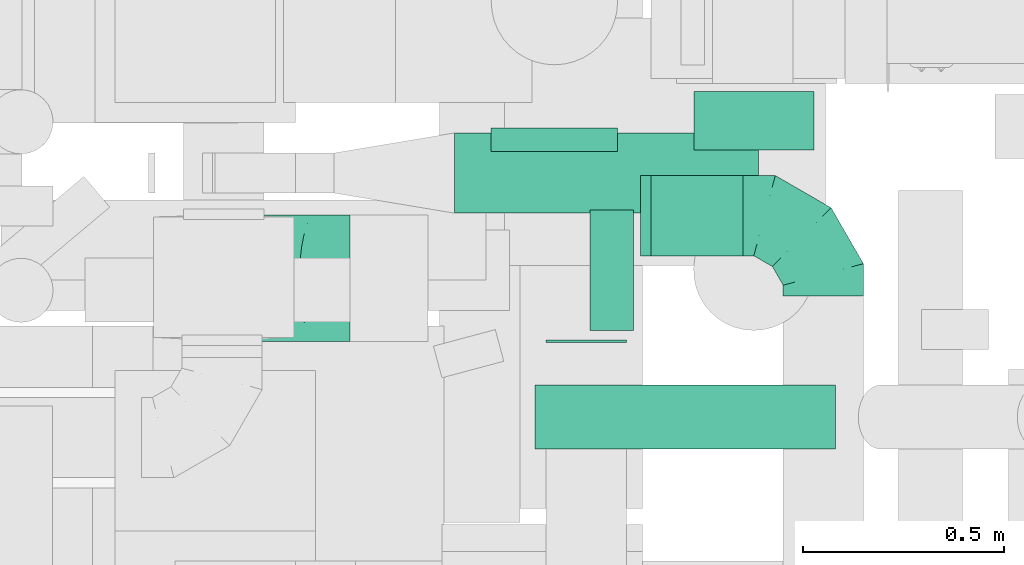
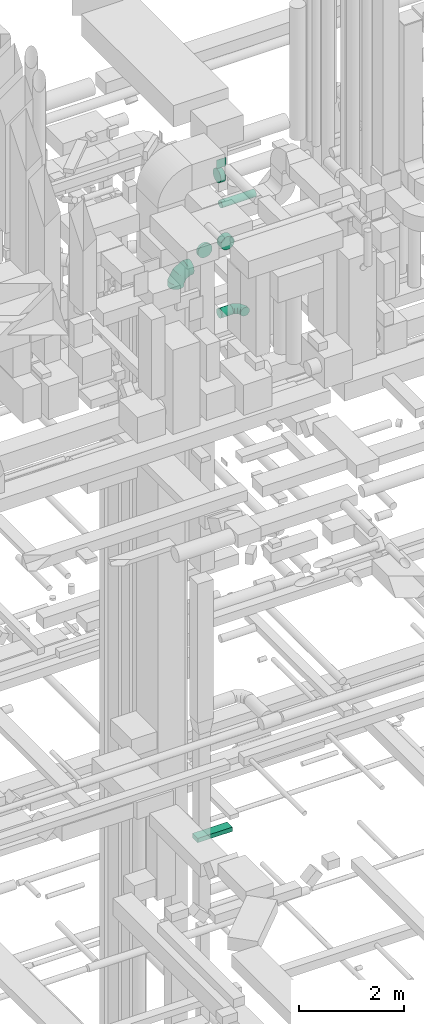
# One storey, part 198 of 337: 7 flow segments, 3 flow fittings.
"""IFC2X3 building model written with IfcOpenShell, lengths in millimetres."""

from ifc_helpers import new_model, entity, si_unit, converted_unit, derived_unit, direction, frame, origin, origin_2d_with_axis, place, context, subcontext, project, spatial, rectangle, circle, extrude, faceted_brep, source, transform, mapped, material, type_object, type_shapes, element, save


model = new_model("IFC2X3")

# Units and contexts
model_context = context("Model", 3, precision=0.01, world=origin(), true_north=direction((6.12303176911189e-17, 1.0)))
body_context = subcontext(model_context, "Body", "Model", "MODEL_VIEW")
ifc_project = project(units=[si_unit("LENGTHUNIT", "METRE", prefix="MILLI"), si_unit("AREAUNIT", "SQUARE_METRE"), si_unit("VOLUMEUNIT", "CUBIC_METRE"), converted_unit("PLANEANGLEUNIT", "DEGREE", entity("IfcRatioMeasure", 0.0174532925199433), si_unit("PLANEANGLEUNIT", "RADIAN"), dimensions=[0, 0, 0, 0, 0, 0, 0]), si_unit("MASSUNIT", "GRAM", prefix="KILO"), derived_unit("MASSDENSITYUNIT", [(si_unit("MASSUNIT", "GRAM", prefix="KILO"), 1), (si_unit("LENGTHUNIT", "METRE"), -3)]), derived_unit("MOMENTOFINERTIAUNIT", [(si_unit("LENGTHUNIT", "METRE"), 4)]), si_unit("TIMEUNIT", "SECOND"), si_unit("FREQUENCYUNIT", "HERTZ"), si_unit("THERMODYNAMICTEMPERATUREUNIT", "DEGREE_CELSIUS"), derived_unit("THERMALTRANSMITTANCEUNIT", [(si_unit("MASSUNIT", "GRAM", prefix="KILO"), 1), (si_unit("THERMODYNAMICTEMPERATUREUNIT", "KELVIN"), -1), (si_unit("TIMEUNIT", "SECOND"), -3)]), derived_unit("VOLUMETRICFLOWRATEUNIT", [(si_unit("LENGTHUNIT", "METRE"), 3), (si_unit("TIMEUNIT", "SECOND"), -1)]), derived_unit("MASSFLOWRATEUNIT", [(si_unit("MASSUNIT", "GRAM", prefix="KILO"), 1), (si_unit("TIMEUNIT", "SECOND"), -1)]), derived_unit("ROTATIONALFREQUENCYUNIT", [(si_unit("TIMEUNIT", "SECOND"), -1)]), si_unit("ELECTRICCURRENTUNIT", "AMPERE"), si_unit("ELECTRICVOLTAGEUNIT", "VOLT"), si_unit("POWERUNIT", "WATT"), si_unit("FORCEUNIT", "NEWTON", prefix="KILO"), si_unit("ILLUMINANCEUNIT", "LUX"), si_unit("LUMINOUSFLUXUNIT", "LUMEN"), si_unit("LUMINOUSINTENSITYUNIT", "CANDELA"), derived_unit("USERDEFINED", [(si_unit("MASSUNIT", "GRAM", prefix="KILO"), -1), (si_unit("LENGTHUNIT", "METRE"), -2), (si_unit("TIMEUNIT", "SECOND"), 3), (si_unit("LUMINOUSFLUXUNIT", "LUMEN"), 1)]), derived_unit("LINEARVELOCITYUNIT", [(si_unit("LENGTHUNIT", "METRE"), 1), (si_unit("TIMEUNIT", "SECOND"), -1)]), si_unit("PRESSUREUNIT", "PASCAL"), derived_unit("USERDEFINED", [(si_unit("LENGTHUNIT", "METRE"), -2), (si_unit("MASSUNIT", "GRAM", prefix="KILO"), 1), (si_unit("TIMEUNIT", "SECOND"), -2)]), derived_unit("LINEARFORCEUNIT", [(si_unit("MASSUNIT", "GRAM", prefix="KILO"), 1), (si_unit("LENGTHUNIT", "METRE"), 1), (si_unit("TIMEUNIT", "SECOND"), -2), (si_unit("LENGTHUNIT", "METRE"), -1)]), derived_unit("PLANARFORCEUNIT", [(si_unit("MASSUNIT", "GRAM", prefix="KILO"), 1), (si_unit("LENGTHUNIT", "METRE"), 1), (si_unit("TIMEUNIT", "SECOND"), -2), (si_unit("LENGTHUNIT", "METRE"), -2)])], contexts=[model_context])

# Site, building, storey
site_placement = place(None, origin())
site = spatial("IfcSite", under=ifc_project, at=site_placement, CompositionType="ELEMENT")
building_placement = place(site_placement, origin())
building = spatial("IfcBuilding", under=site, at=building_placement, CompositionType="ELEMENT")
storey_placement = place(building_placement, origin())
storey = spatial("IfcBuildingStorey", under=building, at=storey_placement, CompositionType="ELEMENT", Elevation=0.0)

# Flow segments
duct_segment_type_1 = type_object("IfcDuctSegmentType", PredefinedType="NOTDEFINED")
flow_segment_1_placement = place(storey_placement, frame((53375.03, 12043.59, 31000.0)))
element("IfcFlowSegment", 1, at=flow_segment_1_placement, inside=storey, type_object=duct_segment_type_1, context=body_context, shape_type="SweptSolid", body=[
    extrude(rectangle(XDim=6.01031825986042, YDim=199.999999999998, at=origin_2d_with_axis()), frame((100.0, 3.01, 0.0), z_axis=(0.0, 0.0, 1.0), x_axis=(0.0, -1.0, 0.0)), (0.0, 0.0, 1.0), 199.999999999998),
])
flow_segment_2_placement = place(storey_placement, frame((53146.97, 12366.31, 15250.0)))
element("IfcFlowSegment", 2, at=flow_segment_2_placement, inside=storey, type_object=duct_segment_type_1, context=body_context, shape_type="SweptSolid", body=[
    extrude(rectangle(XDim=757.00000000007, YDim=200.0, at=origin_2d_with_axis()), frame((378.5, 100.0, 0.0), z_axis=(0.0, 0.0, 1.0), x_axis=(-1.0, 0.0, 0.0)), (0.0, 0.0, 1.0), 99.9999999999989),
])
duct_segment_type_2 = type_object("IfcDuctSegmentType", PredefinedType="NOTDEFINED")
flow_segment_3_placement = place(storey_placement, frame((53635.82, 12258.41, 27273.4)))
element("IfcFlowSegment", 3, at=flow_segment_3_placement, inside=storey, type_object=duct_segment_type_2, context=body_context, shape_type="SweptSolid", body=[
    extrude(circle(Radius=100.0, at=origin_2d_with_axis()), frame((0.0, 101.6, 101.6), z_axis=(1.0, 0.0, 0.0), x_axis=(0.0, 1.0, 0.0)), (0.0, 0.0, 1.0), 230.000000000199),
])
flow_segment_4_placement = place(storey_placement, frame((53484.3, 12072.4, 30548.4)))
element("IfcFlowSegment", 4, at=flow_segment_4_placement, inside=storey, type_object=duct_segment_type_2, context=body_context, shape_type="SweptSolid", body=[
    extrude(circle(Radius=150.0, at=origin_2d_with_axis()), frame((0.0, 151.6, 151.6), z_axis=(1.0, 0.0, 0.0), x_axis=(0.0, 1.0, 0.0)), (0.0, 0.0, 1.0), 108.232830276668),
])
flow_segment_5_placement = place(storey_placement, frame((53740.94, 12524.0, 28655.9)))
element("IfcFlowSegment", 5, at=flow_segment_5_placement, inside=storey, type_object=duct_segment_type_2, context=body_context, shape_type="SweptSolid", body=[
    extrude(circle(Radius=150.0, at=origin_2d_with_axis()), frame((151.6, 0.0, 151.6), z_axis=(0.0, 1.0, 0.0), x_axis=(1.0, 0.0, 0.0)), (0.0, 0.0, 1.0), 145.462665000015),
])
flow_segment_6_placement = place(storey_placement, frame((53236.57, 12519.45, 28648.4)))
element("IfcFlowSegment", 6, at=flow_segment_6_placement, inside=storey, type_object=duct_segment_type_2, context=body_context, shape_type="SweptSolid", body=[
    extrude(circle(Radius=157.5, at=origin_2d_with_axis()), frame((159.1, 0.0, 159.1), z_axis=(0.0, 1.0, 0.0), x_axis=(-1.0, 0.0, 0.0)), (0.0, 0.0, 1.0), 59.0656045891759),
])
flow_segment_7_placement = place(storey_placement, frame((53346.79, 11776.4, 30223.4)))
element("IfcFlowSegment", 7, at=flow_segment_7_placement, inside=storey, type_object=duct_segment_type_2, context=body_context, shape_type="SweptSolid", body=[
    extrude(circle(Radius=80.0, at=origin_2d_with_axis()), frame((0.0, 81.6, 81.6), z_axis=(1.0, 0.0, 0.0), x_axis=(0.0, 1.0, 0.0)), (0.0, 0.0, 1.0), 749.584375133115),
])

# Flow fittings
ifc_material = material()
duct_fitting_type_1 = type_object("IfcDuctFittingType", PredefinedType="NOTDEFINED", material=ifc_material)
shared_shape_1 = source(origin(), body_context, "Body", "Brep", [
    faceted_brep([(-200.0, 0.0, -100.0), (-200.0, -25.88, -96.59), (-200.0, -50.0, -86.6), (-200.0, -70.71, -70.71), (-200.0, -86.6, -50.0), (-200.0, -96.59, -25.88), (-200.0, -100.0, 0.0), (-200.0, -96.59, 25.88), (-200.0, -86.6, 50.0), (-200.0, -70.71, 70.71), (-200.0, -50.0, 86.6), (-200.0, -25.88, 96.59), (-200.0, 0.0, 100.0), (-200.0, 25.88, 96.59), (-200.0, 50.0, 86.6), (-200.0, 70.71, 70.71), (-200.0, 86.6, 50.0), (-200.0, 96.59, 25.88), (-200.0, 100.0, 0.0), (-200.0, 96.59, -25.88), (-200.0, 86.6, -50.0), (-200.0, 70.71, -70.71), (-200.0, 50.0, -86.6), (-200.0, 25.88, -96.59), (-153.35, 25.88, 96.59), (-159.81, 50.0, 86.6), (-146.41, 0.0, 100.0), (-165.36, 70.71, 70.71), (-172.29, 96.59, 25.88), (-173.21, 100.0, 0.0), (-169.62, 86.6, 50.0), (-169.62, 86.6, -50.0), (-165.36, 70.71, -70.71), (-172.29, 96.59, -25.88), (-153.35, 25.88, -96.59), (-146.41, 0.0, -100.0), (-159.81, 50.0, -86.6), (-139.48, -25.88, -96.59), (-133.01, -50.0, -86.6), (-127.46, -70.71, -70.71), (-123.21, -86.6, -50.0), (-120.53, -96.59, -25.88), (-119.62, -100.0, 0.0), (-120.53, -96.59, 25.88), (-123.21, -86.6, 50.0), (-127.46, -70.71, 70.71), (-133.01, -50.0, 86.6), (-139.48, -25.88, 96.59), (-72.54, 72.54, 96.59), (-90.19, 90.19, 86.6), (-53.59, 53.59, 100.0), (-105.35, 105.35, 70.71), (-116.99, 116.99, 50.0), (-124.3, 124.3, 25.88), (-126.79, 126.79, 0.0), (-124.3, 124.3, -25.88), (-116.99, 116.99, -50.0), (-105.35, 105.35, -70.71), (-72.54, 72.54, -96.59), (-53.59, 53.59, -100.0), (-90.19, 90.19, -86.6), (-34.64, 34.64, -96.59), (-16.99, 16.99, -86.6), (-1.83, 1.83, -70.71), (9.81, -9.81, -50.0), (17.12, -17.12, -25.88), (19.62, -19.62, 0.0), (17.12, -17.12, 25.88), (9.81, -9.81, 50.0), (-1.83, 1.83, 70.71), (-16.99, 16.99, 86.6), (-34.64, 34.64, 96.59), (-25.88, 153.35, 96.59), (-50.0, 159.81, 86.6), (0.0, 146.41, 100.0), (-70.71, 165.36, 70.71), (-86.6, 169.62, 50.0), (-96.59, 172.29, 25.88), (-100.0, 173.21, 0.0), (-96.59, 172.29, -25.88), (-86.6, 169.62, -50.0), (-70.71, 165.36, -70.71), (-25.88, 153.35, -96.59), (0.0, 146.41, -100.0), (-50.0, 159.81, -86.6), (25.88, 139.48, -96.59), (50.0, 133.01, -86.6), (70.71, 127.46, -70.71), (86.6, 123.21, -50.0), (96.59, 120.53, -25.88), (100.0, 119.62, 0.0), (96.59, 120.53, 25.88), (86.6, 123.21, 50.0), (70.71, 127.46, 70.71), (50.0, 133.01, 86.6), (25.88, 139.48, 96.59), (-25.88, 200.0, -96.59), (-50.0, 200.0, -86.6), (-70.71, 200.0, -70.71), (-86.6, 200.0, -50.0), (-96.59, 200.0, -25.88), (-100.0, 200.0, 0.0), (-96.59, 200.0, 25.88), (-86.6, 200.0, 50.0), (-70.71, 200.0, 70.71), (-50.0, 200.0, 86.6), (-25.88, 200.0, 96.59), (0.0, 200.0, 100.0), (25.88, 200.0, 96.59), (50.0, 200.0, 86.6), (70.71, 200.0, 70.71), (86.6, 200.0, 50.0), (96.59, 200.0, 25.88), (100.0, 200.0, 0.0), (96.59, 200.0, -25.88), (86.6, 200.0, -50.0), (70.71, 200.0, -70.71), (50.0, 200.0, -86.6), (25.88, 200.0, -96.59), (0.0, 200.0, -100.0)], [[[0, 1, 2, 3, 4, 5, 6, 7, 8, 9, 10, 11, 12, 13, 14, 15, 16, 17, 18, 19, 20, 21, 22, 23]], [[24, 25, 14, 13]], [[26, 24, 13, 12]], [[14, 25, 27, 15]], [[28, 29, 18, 17]], [[30, 28, 17, 16]], [[15, 27, 30, 16]], [[20, 31, 32, 21]], [[33, 31, 20, 19]], [[18, 29, 33, 19]], [[34, 35, 0, 23]], [[36, 34, 23, 22]], [[32, 36, 22, 21]], [[1, 0, 35, 37]], [[2, 1, 37, 38]], [[38, 39, 3, 2]], [[5, 4, 40, 41]], [[6, 5, 41, 42]], [[39, 40, 4, 3]], [[6, 42, 43, 7]], [[7, 43, 44, 8]], [[8, 44, 45, 9]], [[9, 45, 46, 10]], [[10, 46, 47, 11]], [[26, 12, 11, 47]], [[48, 49, 25, 24]], [[50, 48, 24, 26]], [[27, 25, 49, 51]], [[52, 53, 28, 30]], [[51, 52, 30, 27]], [[29, 28, 53, 54]], [[55, 56, 31, 33]], [[54, 55, 33, 29]], [[32, 31, 56, 57]], [[58, 59, 35, 34]], [[60, 58, 34, 36]], [[57, 60, 36, 32]], [[37, 35, 59, 61]], [[38, 37, 61, 62]], [[39, 38, 62, 63]], [[41, 40, 64, 65]], [[42, 41, 65, 66]], [[63, 64, 40, 39]], [[43, 42, 66, 67]], [[44, 43, 67, 68]], [[68, 69, 45, 44]], [[46, 45, 69, 70]], [[47, 46, 70, 71]], [[26, 47, 71, 50]], [[72, 73, 49, 48]], [[74, 72, 48, 50]], [[51, 49, 73, 75]], [[76, 77, 53, 52]], [[75, 76, 52, 51]], [[54, 53, 77, 78]], [[79, 80, 56, 55]], [[78, 79, 55, 54]], [[57, 56, 80, 81]], [[82, 83, 59, 58]], [[84, 82, 58, 60]], [[81, 84, 60, 57]], [[61, 59, 83, 85]], [[62, 61, 85, 86]], [[63, 62, 86, 87]], [[65, 64, 88, 89]], [[66, 65, 89, 90]], [[87, 88, 64, 63]], [[67, 66, 90, 91]], [[68, 67, 91, 92]], [[92, 93, 69, 68]], [[70, 69, 93, 94]], [[71, 70, 94, 95]], [[50, 71, 95, 74]], [[96, 97, 98, 99, 100, 101, 102, 103, 104, 105, 106, 107, 108, 109, 110, 111, 112, 113, 114, 115, 116, 117, 118, 119]], [[72, 74, 107, 106]], [[73, 72, 106, 105]], [[75, 73, 105, 104]], [[102, 101, 78, 77]], [[103, 102, 77, 76]], [[75, 104, 103, 76]], [[78, 101, 100, 79]], [[79, 100, 99, 80]], [[80, 99, 98, 81]], [[84, 97, 96, 82]], [[82, 96, 119, 83]], [[84, 81, 98, 97]], [[118, 117, 86, 85]], [[119, 118, 85, 83]], [[116, 87, 86, 117]], [[88, 115, 114, 89]], [[89, 114, 113, 90]], [[115, 88, 87, 116]], [[91, 90, 113, 112]], [[92, 91, 112, 111]], [[111, 110, 93, 92]], [[95, 94, 109, 108]], [[74, 95, 108, 107]], [[110, 109, 94, 93]]]),
])
type_shapes(duct_fitting_type_1, [shared_shape_1])
flow_fitting_1_placement = place(storey_placement, frame((54065.82, 12360.01, 27375.0), z_axis=(0.0, 0.0, 1.0), x_axis=(0.0, 1.0, 0.0)))
element("IfcFlowFitting", 8, at=flow_fitting_1_placement, inside=storey, type_object=duct_fitting_type_1, material=ifc_material, context=body_context, shape_type="MappedRepresentation", body=[
    mapped(shared_shape_1, transform((0.0, 0.0, 0.0), scale=1.0)),
])
duct_fitting_type_2 = type_object("IfcDuctFittingType", PredefinedType="NOTDEFINED", material=ifc_material)
shared_shape_2 = source(origin(), body_context, "Body", "Brep", [
    faceted_brep([(20.0, 0.0, -100.0), (20.0, 25.88, -96.59), (20.0, 50.0, -86.6), (20.0, 70.71, -70.71), (20.0, 86.6, -50.0), (20.0, 96.59, -25.88), (20.0, 100.0, 0.0), (20.0, 96.59, 25.88), (20.0, 86.6, 50.0), (20.0, 70.71, 70.71), (20.0, 50.0, 86.6), (20.0, 25.88, 96.59), (20.0, 0.0, 100.0), (20.0, -25.88, 96.59), (20.0, -50.0, 86.6), (20.0, -70.71, 70.71), (20.0, -86.6, 50.0), (20.0, -96.59, 25.88), (20.0, -100.0, 0.0), (20.0, -96.59, -25.88), (20.0, -86.6, -50.0), (20.0, -70.71, -70.71), (20.0, -50.0, -86.6), (20.0, -25.88, -96.59), (0.0, 0.0, 100.0), (-6.1, 0.0, 100.0), (-6.1, -25.88, 96.59), (0.0, -25.88, 96.59), (-6.1, -50.0, 86.6), (0.0, -50.0, 86.6), (0.0, -70.71, 70.71), (-6.1, -70.71, 70.71), (0.0, -86.6, 50.0), (-6.1, -86.6, 50.0), (-6.1, -96.59, 25.88), (0.0, -96.59, 25.88), (-6.1, -100.0, 0.0), (0.0, -100.0, 0.0), (-6.1, -96.59, -25.88), (0.0, -96.59, -25.88), (-6.1, -86.6, -50.0), (0.0, -86.6, -50.0), (0.0, -70.71, -70.71), (-6.1, -70.71, -70.71), (0.0, -50.0, -86.6), (-6.1, -50.0, -86.6), (-6.1, -25.88, -96.59), (0.0, -25.88, -96.59), (-6.1, 0.0, -100.0), (0.0, 0.0, -100.0), (-6.1, 25.88, -96.59), (0.0, 25.88, -96.59), (-6.1, 50.0, -86.6), (0.0, 50.0, -86.6), (0.0, 70.71, -70.71), (-6.1, 70.71, -70.71), (0.0, 86.6, -50.0), (-6.1, 86.6, -50.0), (-6.1, 96.59, -25.88), (0.0, 96.59, -25.88), (-6.1, 100.0, 0.0), (0.0, 100.0, 0.0), (-6.1, 96.59, 25.88), (0.0, 96.59, 25.88), (-6.1, 86.6, 50.0), (0.0, 86.6, 50.0), (0.0, 70.71, 70.71), (-6.1, 70.71, 70.71), (0.0, 50.0, 86.6), (-6.1, 50.0, 86.6), (-6.1, 25.88, 96.59), (0.0, 25.88, 96.59)], [[[0, 1, 2, 3, 4, 5, 6, 7, 8, 9, 10, 11, 12, 13, 14, 15, 16, 17, 18, 19, 20, 21, 22, 23]], [[13, 12, 24, 25, 26, 27]], [[14, 13, 27, 26, 28, 29]], [[30, 15, 14, 29, 28, 31]], [[17, 16, 32, 33, 34, 35]], [[18, 17, 35, 34, 36, 37]], [[32, 16, 15, 30, 31, 33]], [[19, 18, 37, 36, 38, 39]], [[20, 19, 39, 38, 40, 41]], [[42, 21, 20, 41, 40, 43]], [[23, 22, 44, 45, 46, 47]], [[0, 23, 47, 46, 48, 49]], [[44, 22, 21, 42, 43, 45]], [[1, 0, 49, 48, 50, 51]], [[2, 1, 51, 50, 52, 53]], [[54, 3, 2, 53, 52, 55]], [[5, 4, 56, 57, 58, 59]], [[6, 5, 59, 58, 60, 61]], [[56, 4, 3, 54, 55, 57]], [[7, 6, 61, 60, 62, 63]], [[8, 7, 63, 62, 64, 65]], [[66, 9, 8, 65, 64, 67]], [[11, 10, 68, 69, 70, 71]], [[12, 11, 71, 70, 25, 24]], [[68, 10, 9, 66, 67, 69]], [[46, 45, 43, 40, 38, 36, 34, 33, 31, 28, 26, 25, 70, 69, 67, 64, 62, 60, 58, 57, 55, 52, 50, 48]]]),
])
type_shapes(duct_fitting_type_2, [shared_shape_2])
flow_fitting_2_placement = place(storey_placement, frame((53615.82, 12360.01, 27375.0), z_axis=(0.0, 0.0, -1.0), x_axis=(1.0, 0.0, 0.0)))
element("IfcFlowFitting", 9, at=flow_fitting_2_placement, inside=storey, type_object=duct_fitting_type_2, material=ifc_material, context=body_context, shape_type="MappedRepresentation", body=[
    mapped(shared_shape_2, transform((0.0, 0.0, 0.0), scale=1.0)),
])
duct_fitting_type_3 = type_object("IfcDuctFittingType", PredefinedType="NOTDEFINED", material=ifc_material)
shared_shape_3 = source(origin(), body_context, "Body", "Brep", [
    faceted_brep([(-315.0, 0.0, -157.5), (-315.0, -40.76, -152.13), (-315.0, -78.75, -136.4), (-315.0, -111.37, -111.37), (-315.0, -136.4, -78.75), (-315.0, -152.13, -40.76), (-315.0, -157.5, 0.0), (-315.0, -152.13, 40.76), (-315.0, -136.4, 78.75), (-315.0, -111.37, 111.37), (-315.0, -78.75, 136.4), (-315.0, -40.76, 152.13), (-315.0, 0.0, 157.5), (-315.0, 40.76, 152.13), (-315.0, 78.75, 136.4), (-315.0, 111.37, 111.37), (-315.0, 136.4, 78.75), (-315.0, 152.13, 40.76), (-315.0, 157.5, 0.0), (-315.0, 152.13, -40.76), (-315.0, 136.4, -78.75), (-315.0, 111.37, -111.37), (-315.0, 78.75, -136.4), (-315.0, 40.76, -152.13), (-241.52, 40.76, 152.13), (-251.7, 78.75, 136.4), (-230.6, 0.0, 157.5), (-260.44, 111.37, 111.37), (-271.36, 152.13, 40.76), (-272.8, 157.5, 0.0), (-267.14, 136.4, 78.75), (-267.14, 136.4, -78.75), (-260.44, 111.37, -111.37), (-271.36, 152.13, -40.76), (-241.52, 40.76, -152.13), (-230.6, 0.0, -157.5), (-251.7, 78.75, -136.4), (-219.67, -40.76, -152.13), (-209.5, -78.75, -136.4), (-200.75, -111.37, -111.37), (-194.05, -136.4, -78.75), (-189.83, -152.13, -40.76), (-188.39, -157.5, 0.0), (-189.83, -152.13, 40.76), (-194.05, -136.4, 78.75), (-200.75, -111.37, 111.37), (-209.5, -78.75, 136.4), (-219.67, -40.76, 152.13), (-114.25, 114.25, 152.13), (-142.05, 142.05, 136.4), (-84.4, 84.4, 157.5), (-165.93, 165.93, 111.37), (-184.25, 184.25, 78.75), (-195.77, 195.77, 40.76), (-199.7, 199.7, 0.0), (-195.77, 195.77, -40.76), (-184.25, 184.25, -78.75), (-165.93, 165.93, -111.37), (-114.25, 114.25, -152.13), (-84.4, 84.4, -157.5), (-142.05, 142.05, -136.4), (-54.56, 54.56, -152.13), (-26.75, 26.75, -136.4), (-2.88, 2.88, -111.37), (15.45, -15.45, -78.75), (26.97, -26.97, -40.76), (30.89, -30.89, 0.0), (26.97, -26.97, 40.76), (15.45, -15.45, 78.75), (-2.88, 2.88, 111.37), (-26.75, 26.75, 136.4), (-54.56, 54.56, 152.13), (-40.76, 241.52, 152.13), (-78.75, 251.7, 136.4), (0.0, 230.6, 157.5), (-111.37, 260.44, 111.37), (-136.4, 267.14, 78.75), (-152.13, 271.36, 40.76), (-157.5, 272.8, 0.0), (-152.13, 271.36, -40.76), (-136.4, 267.14, -78.75), (-111.37, 260.44, -111.37), (-40.76, 241.52, -152.13), (0.0, 230.6, -157.5), (-78.75, 251.7, -136.4), (40.76, 219.67, -152.13), (78.75, 209.5, -136.4), (111.37, 200.75, -111.37), (136.4, 194.05, -78.75), (152.13, 189.83, -40.76), (157.5, 188.39, 0.0), (152.13, 189.83, 40.76), (136.4, 194.05, 78.75), (111.37, 200.75, 111.37), (78.75, 209.5, 136.4), (40.76, 219.67, 152.13), (-40.76, 315.0, -152.13), (-78.75, 315.0, -136.4), (-111.37, 315.0, -111.37), (-136.4, 315.0, -78.75), (-152.13, 315.0, -40.76), (-157.5, 315.0, 0.0), (-152.13, 315.0, 40.76), (-136.4, 315.0, 78.75), (-111.37, 315.0, 111.37), (-78.75, 315.0, 136.4), (-40.76, 315.0, 152.13), (0.0, 315.0, 157.5), (40.76, 315.0, 152.13), (78.75, 315.0, 136.4), (111.37, 315.0, 111.37), (136.4, 315.0, 78.75), (152.13, 315.0, 40.76), (157.5, 315.0, 0.0), (152.13, 315.0, -40.76), (136.4, 315.0, -78.75), (111.37, 315.0, -111.37), (78.75, 315.0, -136.4), (40.76, 315.0, -152.13), (0.0, 315.0, -157.5)], [[[0, 1, 2, 3, 4, 5, 6, 7, 8, 9, 10, 11, 12, 13, 14, 15, 16, 17, 18, 19, 20, 21, 22, 23]], [[24, 25, 14, 13]], [[26, 24, 13, 12]], [[14, 25, 27, 15]], [[28, 29, 18, 17]], [[30, 28, 17, 16]], [[15, 27, 30, 16]], [[20, 31, 32, 21]], [[33, 31, 20, 19]], [[18, 29, 33, 19]], [[34, 35, 0, 23]], [[36, 34, 23, 22]], [[32, 36, 22, 21]], [[1, 0, 35, 37]], [[2, 1, 37, 38]], [[38, 39, 3, 2]], [[5, 4, 40, 41]], [[6, 5, 41, 42]], [[39, 40, 4, 3]], [[6, 42, 43, 7]], [[7, 43, 44, 8]], [[8, 44, 45, 9]], [[9, 45, 46, 10]], [[10, 46, 47, 11]], [[26, 12, 11, 47]], [[48, 49, 25, 24]], [[50, 48, 24, 26]], [[27, 25, 49, 51]], [[52, 53, 28, 30]], [[51, 52, 30, 27]], [[29, 28, 53, 54]], [[55, 56, 31, 33]], [[54, 55, 33, 29]], [[32, 31, 56, 57]], [[58, 59, 35, 34]], [[60, 58, 34, 36]], [[57, 60, 36, 32]], [[37, 35, 59, 61]], [[38, 37, 61, 62]], [[39, 38, 62, 63]], [[41, 40, 64, 65]], [[42, 41, 65, 66]], [[63, 64, 40, 39]], [[43, 42, 66, 67]], [[44, 43, 67, 68]], [[68, 69, 45, 44]], [[46, 45, 69, 70]], [[47, 46, 70, 71]], [[26, 47, 71, 50]], [[72, 73, 49, 48]], [[74, 72, 48, 50]], [[51, 49, 73, 75]], [[76, 77, 53, 52]], [[75, 76, 52, 51]], [[54, 53, 77, 78]], [[79, 80, 56, 55]], [[78, 79, 55, 54]], [[57, 56, 80, 81]], [[82, 83, 59, 58]], [[84, 82, 58, 60]], [[81, 84, 60, 57]], [[61, 59, 83, 85]], [[62, 61, 85, 86]], [[63, 62, 86, 87]], [[65, 64, 88, 89]], [[66, 65, 89, 90]], [[87, 88, 64, 63]], [[67, 66, 90, 91]], [[68, 67, 91, 92]], [[92, 93, 69, 68]], [[70, 69, 93, 94]], [[71, 70, 94, 95]], [[50, 71, 95, 74]], [[96, 97, 98, 99, 100, 101, 102, 103, 104, 105, 106, 107, 108, 109, 110, 111, 112, 113, 114, 115, 116, 117, 118, 119]], [[106, 105, 73, 72]], [[107, 106, 72, 74]], [[75, 73, 105, 104]], [[77, 76, 103, 102]], [[78, 77, 102, 101]], [[104, 103, 76, 75]], [[78, 101, 100, 79]], [[79, 100, 99, 80]], [[98, 81, 80, 99]], [[84, 97, 96, 82]], [[82, 96, 119, 83]], [[97, 84, 81, 98]], [[83, 119, 118, 85]], [[85, 118, 117, 86]], [[116, 87, 86, 117]], [[88, 115, 114, 89]], [[89, 114, 113, 90]], [[115, 88, 87, 116]], [[91, 90, 113, 112]], [[92, 91, 112, 111]], [[111, 110, 93, 92]], [[95, 94, 109, 108]], [[74, 95, 108, 107]], [[110, 109, 94, 93]]]),
])
type_shapes(duct_fitting_type_3, [shared_shape_3])
flow_fitting_3_placement = place(storey_placement, frame((52571.74, 12204.45, 28807.5), z_axis=(0.0, -1.0, 0.0), x_axis=(-1.0, 0.0, 0.0)))
element("IfcFlowFitting", 10, at=flow_fitting_3_placement, inside=storey, type_object=duct_fitting_type_3, material=ifc_material, context=body_context, shape_type="MappedRepresentation", body=[
    mapped(shared_shape_3, transform((0.0, 0.0, 0.0), scale=1.0)),
])

save(model, "model.ifc")
